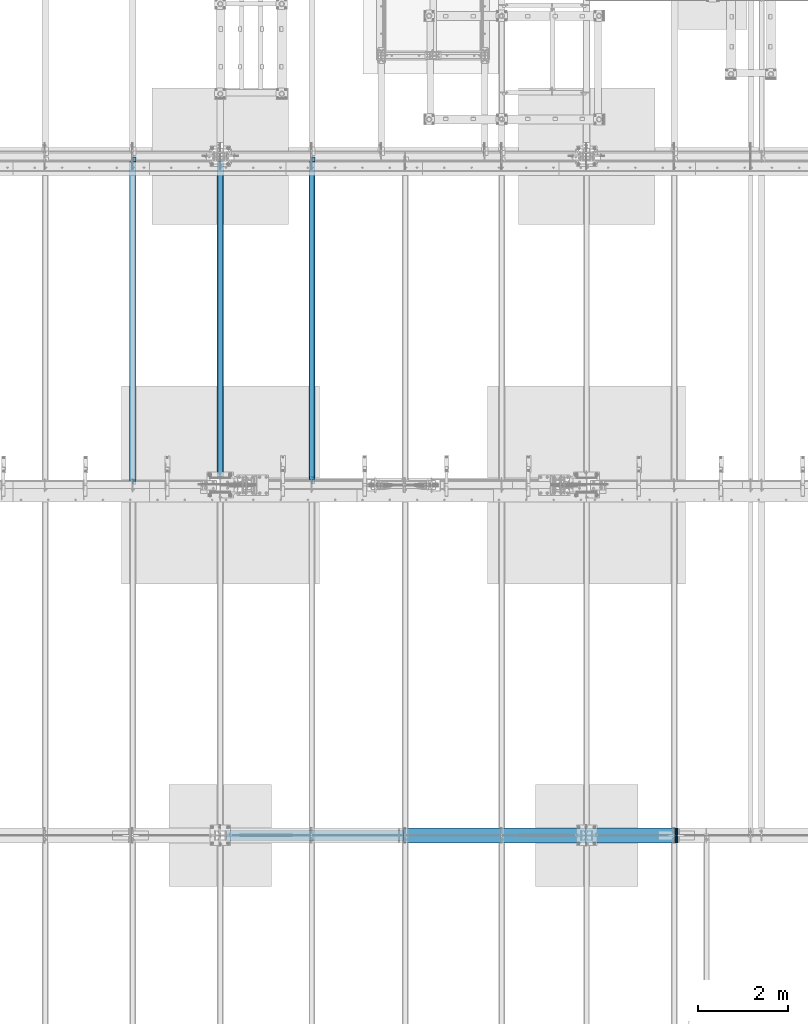
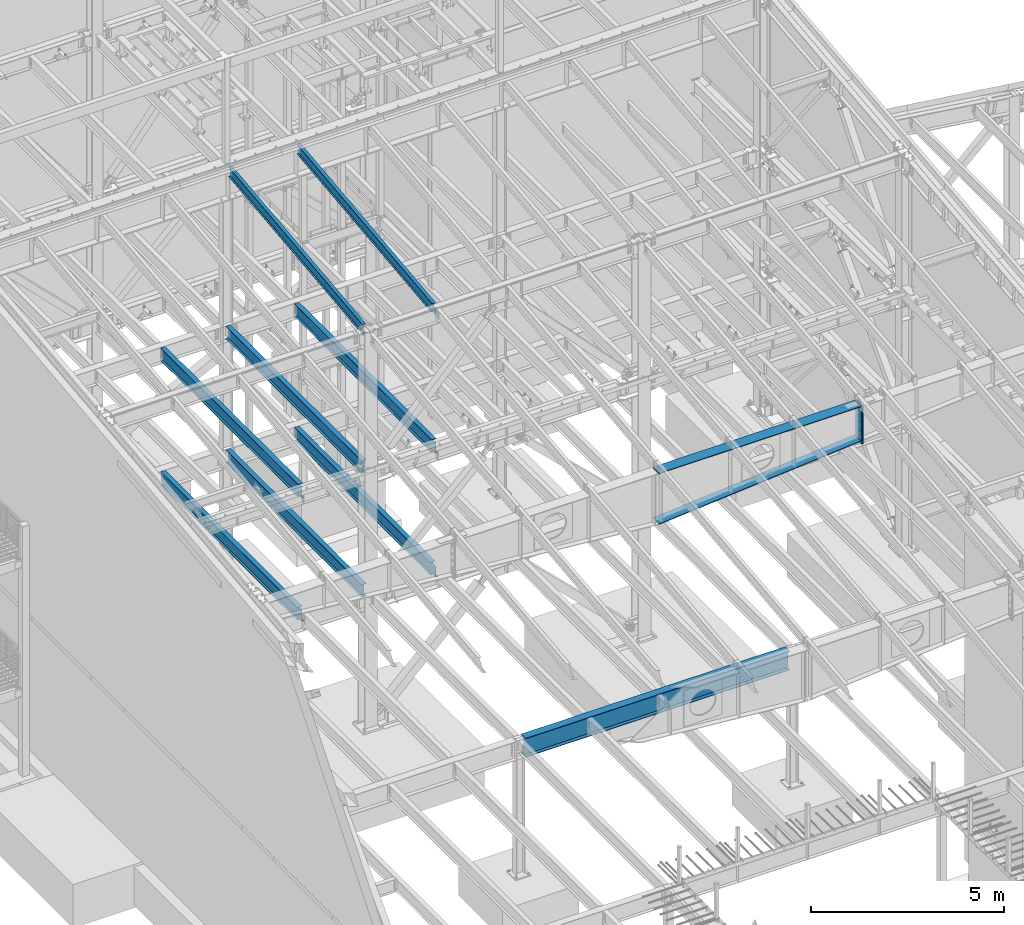
# One storey, part 733 of 1179: 13 beams, 11 elements without a shape of their own.
"""IFC2X3 building model written with IfcOpenShell, lengths in millimetres."""

import ifcopenshell
import ifcopenshell.guid

model = None  # the IFC model being written
_history = None  # IfcOwnerHistory: only IFC2X3 demands one
_inside = {}  # id of a spatial element -> (the spatial element, [elements in it])
_under = {}  # id of a project, library or spatial element -> (it, [spatial elements below it])
_declared = {}  # id of a project -> (the project, [libraries it declares])
_typed = {}  # id of a type object -> (the type object, [elements of that type])
_made_of = {}  # id of a material, layer set ... -> (it, [elements and type objects made of it])


def new_model(schema):
    """Start an empty IFC model of exactly this schema.

    Asked for "IFC4X3", IfcOpenShell would pick the latest addendum, in which some entities
    have other attributes; the version numbers below select the first issue.
    IFC2X3 requires an IfcOwnerHistory on every rooted entity: one is made here for all.
    """
    global model, _history
    if schema == "IFC4X3":
        model = ifcopenshell.file(schema_version=(4, 3, 0, 0))
    else:
        model = ifcopenshell.file(schema=schema)
    _inside.clear()
    _under.clear()
    _declared.clear()
    _typed.clear()
    _made_of.clear()
    _history = None
    if model.schema == "IFC2X3":
        org = make("IfcOrganization", Name="unknown")
        user = make(
            "IfcPersonAndOrganization",
            ThePerson=make("IfcPerson", FamilyName="unknown"),
            TheOrganization=org,
        )
        app = make(
            "IfcApplication",
            ApplicationDeveloper=org,
            Version="unknown",
            ApplicationFullName="unknown",
            ApplicationIdentifier="unknown",
        )
        _history = make(
            "IfcOwnerHistory",
            OwningUser=user,
            OwningApplication=app,
            ChangeAction="ADDED",
            CreationDate=0,
        )
    return model


def make(cls, **values):
    """One entity of the class cls with the attributes given. An attribute that is None is left unset."""
    return model.create_entity(
        cls, **{name: value for name, value in values.items() if value is not None}
    )


def rooted(cls, **values):
    """An entity with a GlobalId (a new one), such as an element, a storey or a relation."""
    return make(cls, GlobalId=ifcopenshell.guid.new(), OwnerHistory=_history, **values)


def si_unit(unit_type, name, prefix=None):
    """IfcSIUnit, for example si_unit("LENGTHUNIT", "METRE", prefix="MILLI")."""
    return make("IfcSIUnit", UnitType=unit_type, Prefix=prefix, Name=name)


def assignment(units):
    """IfcUnitAssignment: the units of a project."""
    return None if units is None else make("IfcUnitAssignment", Units=units)


def point(xyz):
    """IfcCartesianPoint."""
    return None if xyz is None else make("IfcCartesianPoint", Coordinates=xyz)


def direction(xyz):
    """IfcDirection."""
    return None if xyz is None else make("IfcDirection", DirectionRatios=xyz)


def frame(location, z_axis=None, x_axis=None):
    """IfcAxis2Placement3D, a coordinate frame: its origin and axes. An axis left out is left unset."""
    return make(
        "IfcAxis2Placement3D",
        Location=point(location),
        Axis=direction(z_axis),
        RefDirection=direction(x_axis),
    )


def origin_with_axes():
    """The frame at (0, 0, 0) with the z axis (0, 0, 1) and the x axis (1, 0, 0) written out."""
    return frame((0.0, 0.0, 0.0), z_axis=(0.0, 0.0, 1.0), x_axis=(1.0, 0.0, 0.0))


def place(relative_to, where):
    """IfcLocalPlacement: puts the frame where relative to a parent placement (None: the world)."""
    return make(
        "IfcLocalPlacement", PlacementRelTo=relative_to, RelativePlacement=where
    )


def context(
    kind, dimensions, precision=None, world=None, true_north=None, identifier=None
):
    """IfcGeometricRepresentationContext, for example the 3D "Model" context."""
    return make(
        "IfcGeometricRepresentationContext",
        ContextIdentifier=identifier,
        ContextType=kind,
        CoordinateSpaceDimension=dimensions,
        Precision=precision,
        WorldCoordinateSystem=world,
        TrueNorth=true_north,
    )


def subcontext(parent, identifier, kind, view, scale=None):
    """IfcGeometricRepresentationSubContext, for example "Body" below "Model"."""
    return make(
        "IfcGeometricRepresentationSubContext",
        ContextIdentifier=identifier,
        ContextType=kind,
        ParentContext=parent,
        TargetScale=scale,
        TargetView=view,
    )


def project(units=None, contexts=None):
    """IfcProject with its units and contexts."""
    return rooted(
        "IfcProject",
        Name="project",
        RepresentationContexts=contexts,
        UnitsInContext=assignment(units),
    )


def spatial(cls, under=None, at=None, **own):
    """A site, building, storey or space (cls), placed at a placement, below another one or the project."""
    s = rooted(cls, ObjectPlacement=at, **own)
    if under is not None:
        _under.setdefault(under.id(), (under, []))[1].append(s)
    return s


def faces_of(points, faces, orient=None, outer=None):
    """IfcFace entities. A face is a list of loops; a loop is a list of indices into points, from 0.

    orient and outer hold one flag for each loop. By default every Orientation is true, the
    first loop of a face is its IfcFaceOuterBound and the others are IfcFaceBound.
    """
    made = []
    for i, loops in enumerate(faces):
        bounds = []
        for j, loop in enumerate(loops):
            is_outer = j == 0 if outer is None else outer[i][j]
            bounds.append(
                make(
                    "IfcFaceOuterBound" if is_outer else "IfcFaceBound",
                    Bound=make("IfcPolyLoop", Polygon=[points[k] for k in loop]),
                    Orientation=True if orient is None else orient[i][j],
                )
            )
        made.append(make("IfcFace", Bounds=bounds))
    return made


def faceted_brep(points, faces, orient=None, outer=None, voids=None):
    """IfcFacetedBrep: a solid bounded by flat faces; with voids (closed shells), ...WithVoids."""
    shared = [point(p) for p in points]
    hull = make("IfcClosedShell", CfsFaces=faces_of(shared, faces, orient, outer))
    if voids is None:
        return make("IfcFacetedBrep", Outer=hull)
    return make(
        "IfcFacetedBrepWithVoids",
        Outer=hull,
        Voids=[
            make(cls, CfsFaces=faces_of(shared, fs, o, b)) for cls, fs, o, b in voids
        ],
    )


def shape(context_of_items, identifier, shape_type, items):
    """IfcShapeRepresentation: the items that make up one representation, for example the "Body"."""
    return make(
        "IfcShapeRepresentation",
        ContextOfItems=context_of_items,
        RepresentationIdentifier=identifier,
        RepresentationType=shape_type,
        Items=items,
    )


def material(Name=None, Category=None):
    """IfcMaterial."""
    return make("IfcMaterial", Name=Name, Category=Category)


def made_of(thing, what):
    """Note that an element or type object is made of a material, layer set ...; save() writes the relation."""
    if what is not None:
        _made_of.setdefault(what.id(), (what, []))[1].append(thing)
    return thing


def type_object(cls, material=None, **own):
    """A type object (cls), such as IfcWallType, which elements share."""
    return made_of(rooted(cls, **own), material)


def element(
    cls,
    number,
    at=None,
    inside=None,
    cuts=None,
    type_object=None,
    material=None,
    context=None,
    identifier="Body",
    shape_type=None,
    held_by="IfcProductDefinitionShape",
    body=None,
    shapes=None,
    **own,
):
    """One element of the class cls, such as IfcWall. Its Tag is "e" and its number.

    at: its placement. inside: the storey or other place that contains it. cuts: it is an
    opening in that element (IfcRelVoidsElement). A single representation is given by context,
    identifier, shape_type and body (its items); several are given by shapes. held_by: the class
    of the entity that holds the representations. save() writes the other relations.
    """
    e = rooted(cls, Tag="e%d" % number, ObjectPlacement=at, **own)
    if body is not None:
        shapes = [shape(context, identifier, shape_type, body)]
    if shapes is not None:
        e.Representation = make(held_by, Representations=shapes)
    if inside is not None:
        _inside.setdefault(inside.id(), (inside, []))[1].append(e)
    if cuts is not None:
        rooted(
            "IfcRelVoidsElement", RelatingBuildingElement=cuts, RelatedOpeningElement=e
        )
    if type_object is not None:
        _typed.setdefault(type_object.id(), (type_object, []))[1].append(e)
    return made_of(e, material)


def aggregate(whole, parts):
    """IfcRelAggregates: a whole, such as a stair, and the parts it consists of."""
    return rooted("IfcRelAggregates", RelatingObject=whole, RelatedObjects=parts)


def save(model, path):
    """Write the relations noted so far, then the file.

    IfcRelAggregates (storeys below a building ...), IfcRelContainedInSpatialStructure (elements
    in a storey), IfcRelDefinesByType, IfcRelAssociatesMaterial and IfcRelDeclares: one each for
    every whole, place, type object, material and project.
    """
    for whole, parts in _under.values():
        aggregate(whole, parts)
    for where, things in _inside.values():
        rooted(
            "IfcRelContainedInSpatialStructure",
            RelatedElements=things,
            RelatingStructure=where,
        )
    for kind, things in _typed.values():
        rooted("IfcRelDefinesByType", RelatedObjects=things, RelatingType=kind)
    for what, things in _made_of.values():
        rooted("IfcRelAssociatesMaterial", RelatedObjects=things, RelatingMaterial=what)
    for by, libraries in _declared.values():
        rooted("IfcRelDeclares", RelatingContext=by, RelatedDefinitions=libraries)
    model.write(path)


model = new_model("IFC2X3")

# Units and contexts
model_context = context("Model", 3, precision=1e-05, world=origin_with_axes())
body_context = subcontext(model_context, "Body", "Model", "MODEL_VIEW")
ifc_project = project(units=[si_unit("LENGTHUNIT", "METRE", prefix="MILLI"), si_unit("AREAUNIT", "SQUARE_METRE"), si_unit("VOLUMEUNIT", "CUBIC_METRE"), si_unit("MASSUNIT", "GRAM", prefix="KILO"), si_unit("TIMEUNIT", "SECOND"), si_unit("PLANEANGLEUNIT", "RADIAN"), si_unit("SOLIDANGLEUNIT", "STERADIAN"), si_unit("THERMODYNAMICTEMPERATUREUNIT", "DEGREE_CELSIUS"), si_unit("LUMINOUSINTENSITYUNIT", "LUMEN")], contexts=[model_context])

# Site, building, storey
site_placement = place(None, origin_with_axes())
site = spatial("IfcSite", under=ifc_project, at=site_placement, CompositionType="ELEMENT")
building_placement = place(site_placement, origin_with_axes())
building = spatial("IfcBuilding", under=site, at=building_placement, Name="Undefined", CompositionType="ELEMENT")
storey_placement = place(building_placement, origin_with_axes())
storey = spatial("IfcBuildingStorey", under=building, at=storey_placement, Name="Undefined", CompositionType="ELEMENT", Elevation=0.0)

# Assembly, beam
assembly_1_placement = place(storey_placement, origin_with_axes())
assembly_1 = element("IfcElementAssembly", 1, at=assembly_1_placement, inside=storey, Name="BEAM", AssemblyPlace="NOTDEFINED", PredefinedType="RIGID_FRAME")
ifc_material_1 = material(Name="STEEL/A992")
beam_type_1 = type_object("IfcBeamType", Name="W16X31", PredefinedType="NOTDEFINED")
beam_1_placement = place(assembly_1_placement, frame((10325.1, 27051.0, 7812.0875), z_axis=(0.0, 0.0, 1.0), x_axis=(0.0, 1.0, 0.0)))
beam_1 = element("IfcBeam", 2, at=beam_1_placement, type_object=beam_type_1, material=ifc_material_1, Name="BEAM", ObjectType="W16X31", context=body_context, shape_type="Brep", body=[
    faceted_brep([(105.568750190734, -3.17499999999927, 157.1625), (105.568750190734, 3.17498369619716, 157.1625), (19.84375, 3.17499999999927, 157.1625), (19.84375, -3.17499999999927, 157.1625), (110.428829708781, -3.17499999999927, 158.129229922588), (110.428829708781, 3.17498323778818, 158.129229922588), (114.549006176934, -3.17499999999927, 160.882243823066), (114.549006176934, 3.17498193235224, 160.882243823066), (117.302020077412, -3.17499999999927, 165.00242029122), (117.302020077412, 3.17497997862665, 165.00242029122), (118.268749999999, -3.17499999999927, 169.862499809266), (118.268749999999, 3.17497767405257, 169.862499809266), (118.268749999999, -69.8500000000004, 201.6125), (118.268749999999, 69.8500000000004, 201.6125), (118.268749999999, 69.8500000000004, 190.5), (118.268749999999, 3.17499999999927, 190.5), (118.268749999999, -3.17499999999927, 190.5), (118.268749999999, -69.8500000000004, 190.5), (7196.1375, 3.17499999999927, -190.5), (7196.1375, 69.8500000000004, -190.5), (146.84375, 69.8500000000004, -190.5), (146.843749999996, 3.17549991607484, -190.5), (19.84375, -3.17499999999927, -190.5), (19.84375, -69.8500000000004, -190.5), (7323.1375, -69.8500000000004, -190.5), (7323.1375, -3.17499999999927, -190.5), (19.84375, -69.8500000000004, -201.6125), (7323.1375, -69.8500000000004, -201.6125), (7196.1375, 69.8500000000004, -201.6125), (7196.1375, 3.17549991607484, -201.6125), (7323.1375, 3.17549991607484, -201.6125), (19.84375, 3.17549991607484, -201.6125), (146.843749999996, 3.17549991607484, -201.6125), (146.84375, 69.8500000000004, -201.6125), (19.84375, 3.17499999999927, -190.5), (7323.1375, 3.17499999999927, -190.5), (7323.1375, 3.17499999999927, 166.6875), (7323.1375, -3.17499999999927, 166.6875), (7235.82499980928, 3.17499999999927, 166.6875), (7235.82499980928, -3.17499999999927, 166.6875), (7230.96492029123, 3.17499999999927, 167.654229922588), (7230.96492029123, -3.17499999999927, 167.654229922588), (7226.84474382308, 3.17499999999927, 170.407243823066), (7226.84474382308, -3.17499999999927, 170.407243823066), (7224.0917299226, 3.17499999999927, 174.52742029122), (7224.0917299226, -3.17499999999927, 174.52742029122), (7223.12500000001, 3.17499999999927, 179.387499809265), (7223.12500000001, -3.17499999999927, 179.387499809265), (7223.12500000001, -69.8500000000004, 201.6125), (7223.12500000001, -69.8500000000004, 190.5), (7223.12500000001, -3.17499999999927, 190.5), (7223.12500000001, 3.17499999999927, 190.5), (7223.12500000001, 69.8500000000004, 190.5), (7223.12500000001, 69.8500000000004, 201.6125)], [[[0, 1, 2, 3]], [[4, 5, 1, 0]], [[6, 7, 5, 4]], [[8, 9, 7, 6]], [[10, 11, 9, 8]], [[12, 13, 14, 15, 11, 10, 16, 17]], [[18, 19, 20, 21]], [[22, 23, 24, 25]], [[23, 26, 27, 24]], [[28, 29, 30, 27, 26, 31, 32, 33]], [[21, 32, 31, 34]], [[20, 33, 32, 21]], [[19, 28, 33, 20]], [[18, 29, 28, 19]], [[35, 30, 29, 18]], [[25, 24, 27, 30, 35, 36, 37]], [[37, 36, 38, 39]], [[39, 38, 40, 41]], [[41, 40, 42, 43]], [[43, 42, 44, 45]], [[45, 44, 46, 47]], [[48, 49, 50, 47, 46, 51, 52, 53]], [[49, 48, 12, 17]], [[50, 49, 17, 16]], [[8, 6, 4, 0, 3, 22, 25, 37, 39, 41, 43, 45, 47, 50, 16, 10]], [[34, 31, 26, 23, 22, 3, 2]], [[51, 46, 44, 42, 40, 38, 36, 35, 18, 21, 34, 2, 1, 5, 7, 9, 11, 15]], [[52, 51, 15, 14]], [[53, 52, 14, 13]], [[48, 53, 13, 12]]]),
])
aggregate(assembly_1, [beam_1])

assembly_2_placement = place(storey_placement, origin_with_axes())
assembly_2 = element("IfcElementAssembly", 3, at=assembly_2_placement, inside=storey, Name="BEAM", AssemblyPlace="NOTDEFINED", PredefinedType="RIGID_FRAME")
beam_2_placement = place(assembly_2_placement, frame((8280.4, 27051.0, 7812.0875), z_axis=(0.0, 0.0, 1.0), x_axis=(0.0, 1.0, 0.0)))
beam_2 = element("IfcBeam", 4, at=beam_2_placement, type_object=beam_type_1, material=ifc_material_1, Name="BEAM", ObjectType="W16X31", context=body_context, shape_type="Brep", body=[
    faceted_brep([(195.262500000001, -69.8499999999985, -201.6125), (195.262500000001, 69.8499999999985, -201.6125), (7224.7125, 69.8499999999985, -201.6125), (7224.7125, -69.8499999999985, -201.6125), (195.262500000001, -69.8499999999985, -190.5), (195.262500000001, -3.17499999999927, -190.5), (195.262500000001, -3.17499999999927, 190.5), (195.262500000001, -69.8499999999985, 190.5), (195.262500000001, -69.8499999999985, 201.6125), (195.262500000001, 69.8499999999985, 201.6125), (195.262500000001, 69.8499999999985, 190.5), (195.262500000001, 3.17499999999927, 190.5), (195.262500000001, 3.17499999999927, -190.5), (195.262500000001, 69.8499999999985, -190.5), (7224.7125, -69.8499999999985, -190.5), (7224.7125, -3.17499999999927, -190.5), (7224.7125, -3.17499999999927, 190.5), (7224.7125, -69.8499999999985, 190.5), (7224.7125, -69.8499999999985, 201.6125), (7224.7125, 69.8499999999985, 201.6125), (7224.7125, 69.8499999999985, 190.5), (7224.7125, 3.17499999999927, 190.5), (7224.7125, 3.17499999999927, 164.252489941818), (7224.7125, 3.17499999999927, -142.027503290603), (7224.7125, 3.17499999999927, -190.5), (7224.7125, 69.8499999999985, -190.5)], [[[0, 1, 2, 3]], [[0, 4, 5, 6, 7, 8, 9, 10, 11, 12, 13, 1]], [[5, 4, 14, 15]], [[6, 5, 15, 16]], [[7, 6, 16, 17]], [[8, 7, 17, 18]], [[9, 8, 18, 19]], [[10, 9, 19, 20]], [[11, 10, 20, 21]], [[12, 11, 21, 22, 23, 24]], [[13, 12, 24, 25]], [[1, 13, 25, 2]], [[24, 23, 22, 21, 20, 19, 18, 17, 16, 15, 14, 3, 2, 25]], [[4, 0, 3, 14]]]),
])
aggregate(assembly_2, [beam_2])

assembly_3_placement = place(storey_placement, origin_with_axes())
assembly_3 = element("IfcElementAssembly", 5, at=assembly_3_placement, inside=storey, Name="BEAM", AssemblyPlace="NOTDEFINED", PredefinedType="RIGID_FRAME")
beam_3_placement = place(assembly_3_placement, frame((6324.6, 27051.0, 7812.0875), z_axis=(0.0, 0.0, 1.0), x_axis=(0.0, 1.0, 0.0)))
beam_3 = element("IfcBeam", 6, at=beam_3_placement, type_object=beam_type_1, material=ifc_material_1, Name="BEAM", ObjectType="W16X31", context=body_context, shape_type="Brep", body=[
    faceted_brep([(82.5499999999993, -3.17500000000291, 166.6875), (82.5499999999993, 3.17500000000291, 166.6875), (17.4624999999942, 3.17499999999927, 166.6875), (17.4624999999942, -3.17499999999927, 166.6875), (87.4100797087813, -3.17499999999927, 167.654229922588), (87.4100797087813, 3.17497144083973, 167.654229922588), (91.5302561769349, -3.17499999999927, 170.407243823066), (91.5302561769349, 3.17496966460385, 170.407243823066), (94.2832700774125, -3.17499999999927, 174.52742029122), (94.2832700774125, 3.1749670062818, 174.52742029122), (95.25, -3.17499999999927, 179.387499809265), (95.25, 3.1749638705769, 179.387499809265), (95.25, -69.8499999999985, 201.6125), (95.25, 69.8499999999985, 201.6125), (95.25, 69.8499999999985, 190.5), (95.25, 3.17499999999927, 190.5), (95.25, -3.17499999999927, 190.5), (95.25, -69.8499999999985, 190.5), (7196.1375, 3.17499999999927, -190.5), (7196.1375, 69.8500000000004, -190.5), (144.462499999994, 69.8499999999985, -190.5), (144.462499999994, 3.17549991607666, -190.5), (17.4624999999942, -3.17499999999927, -190.5), (17.4624999999942, -69.8499999999985, -190.5), (7323.1375, -69.8500000000004, -190.5), (7323.1375, -3.17499999999927, -190.5), (17.4624999999942, -69.8499999999985, -201.6125), (7323.1375, -69.8500000000004, -201.6125), (7196.1375, 69.8500000000004, -201.6125), (7196.1375, 3.17549991607484, -201.6125), (7323.1375, 3.17549991607484, -201.6125), (17.4624999999942, 3.17549991607666, -201.6125), (144.462499999994, 3.17549991607666, -201.6125), (144.462499999994, 69.8499999999985, -201.6125), (17.4624999999942, 3.17499999999927, -190.5), (7323.1375, 3.17499999999927, -190.5), (7323.1375, 3.17499999999927, 166.6875), (7323.1375, -3.17499999999927, 166.6875), (7235.82499980928, 3.17499999999927, 166.6875), (7235.82499980928, -3.17499999999927, 166.6875), (7230.96492029123, 3.17499999999927, 167.654229922588), (7230.96492029123, -3.17499999999927, 167.654229922588), (7226.84474382308, 3.17499999999927, 170.407243823066), (7226.84474382308, -3.17499999999927, 170.407243823066), (7224.0917299226, 3.17499999999927, 174.52742029122), (7224.0917299226, -3.17499999999927, 174.52742029122), (7223.12500000001, 3.17499999999927, 179.387499809265), (7223.12500000001, -3.17499999999927, 179.387499809265), (7223.12500000001, -69.8500000000004, 201.6125), (7223.12500000001, -69.8500000000004, 190.5), (7223.12500000001, -3.17499999999927, 190.5), (7223.12500000001, 3.17499999999927, 190.5), (7223.12500000001, 69.8500000000004, 190.5), (7223.12500000001, 69.8500000000004, 201.6125)], [[[0, 1, 2, 3]], [[4, 5, 1, 0]], [[6, 7, 5, 4]], [[8, 9, 7, 6]], [[10, 11, 9, 8]], [[12, 13, 14, 15, 11, 10, 16, 17]], [[18, 19, 20, 21]], [[22, 23, 24, 25]], [[23, 26, 27, 24]], [[28, 29, 30, 27, 26, 31, 32, 33]], [[21, 32, 31, 34]], [[20, 33, 32, 21]], [[19, 28, 33, 20]], [[18, 29, 28, 19]], [[35, 30, 29, 18]], [[25, 24, 27, 30, 35, 36, 37]], [[37, 36, 38, 39]], [[39, 38, 40, 41]], [[41, 40, 42, 43]], [[43, 42, 44, 45]], [[45, 44, 46, 47]], [[48, 49, 50, 47, 46, 51, 52, 53]], [[49, 48, 12, 17]], [[50, 49, 17, 16]], [[8, 6, 4, 0, 3, 22, 25, 37, 39, 41, 43, 45, 47, 50, 16, 10]], [[34, 31, 26, 23, 22, 3, 2]], [[51, 46, 44, 42, 40, 38, 36, 35, 18, 21, 34, 2, 1, 5, 7, 9, 11, 15]], [[52, 51, 15, 14]], [[53, 52, 14, 13]], [[48, 53, 13, 12]]]),
])
aggregate(assembly_3, [beam_3])

assembly_4_placement = place(storey_placement, origin_with_axes())
assembly_4 = element("IfcElementAssembly", 7, at=assembly_4_placement, inside=storey, Name="BEAM", AssemblyPlace="NOTDEFINED", PredefinedType="RIGID_FRAME")
beam_4_placement = place(assembly_4_placement, frame((10325.1001686096, 27046.2375, 3900.4875), z_axis=(0.0, 0.0, 1.0), x_axis=(0.0, 1.0, 0.0)))
beam_4 = element("IfcBeam", 8, at=beam_4_placement, type_object=beam_type_1, material=ifc_material_1, Name="BEAM", ObjectType="W16X31", context=body_context, shape_type="Brep", body=[
    faceted_brep([(168.275000190741, -3.17499999999927, 163.512499999999), (168.275000190741, 3.17497466870009, 163.512499999999), (25.4000000000015, 3.17499999999927, 163.512499999999), (25.4000000000015, -3.17499999999927, 163.512499999999), (173.135079708787, -3.17499999999927, 164.479229922587), (173.135079708787, 3.17497404500864, 164.479229922587), (177.255256176941, -3.17499999999927, 167.232243823065), (177.255256176941, 3.17497226888918, 167.232243823065), (180.008270077418, -3.17499999999927, 171.352420291219), (180.008270077418, 3.17496961073812, 171.352420291219), (180.975000000006, -3.17499999999927, 176.212499809265), (180.975000000006, 3.1749664752333, 176.212499809265), (180.975000000006, -69.8500000000004, 201.6125), (180.975000000006, 69.8500000000004, 201.6125), (180.975000000006, 69.8500000000004, 190.5), (180.975000000006, 3.17499999999927, 190.5), (180.975000000006, -3.17499999999927, 190.5), (180.975000000006, -69.8500000000004, 190.5), (7200.10625, 3.17499999999927, -190.5), (7200.10625, 69.8500000000004, -190.5), (180.975000000002, 69.8500000000004, -190.5), (180.975000000002, 3.17549991607484, -190.5), (25.4000000000015, -3.17499999999927, -190.5), (25.4000000000015, -69.8500000000004, -190.5), (7327.10625, -69.8500000000004, -190.5), (7327.10625, -3.17499999999927, -190.5), (25.4000000000015, -69.8500000000004, -201.6125), (7327.10625, -69.8500000000004, -201.6125), (7200.10625, 69.8500000000004, -201.6125), (7200.10625, 3.17549991607666, -201.6125), (7327.10625, 3.17549991607666, -201.6125), (25.4000000000015, 3.17549991607484, -201.6125), (180.975000000002, 3.17549991607484, -201.6125), (180.975000000002, 69.8500000000004, -201.6125), (25.4000000000015, 3.17499999999927, -190.5), (7327.10625, 3.17499999999927, -190.5), (7327.10625, 3.17499999999927, 169.8625), (7327.10625, -3.17499999999927, 169.8625), (7231.85624980925, 3.17499999999927, 169.8625), (7231.85624980925, -3.17499999999927, 169.8625), (7226.99617029121, 3.17499999999927, 170.829229922588), (7226.99617029121, -3.17499999999927, 170.829229922588), (7222.87599382305, 3.17499999999927, 173.582243823066), (7222.87599382305, -3.17499999999927, 173.582243823066), (7220.12297992257, 3.17499999999927, 177.70242029122), (7220.12297992257, -3.17499999999927, 177.70242029122), (7219.15624999999, 3.17499999999927, 182.562499809265), (7219.15624999999, -3.17499999999927, 182.562499809265), (7219.15624999999, -69.8500000000004, 201.6125), (7219.15624999999, -69.8500000000004, 190.5), (7219.15624999999, -3.17499999999927, 190.5), (7219.15624999999, 3.17499999999927, 190.5), (7219.15624999999, 69.8500000000004, 190.5), (7219.15624999999, 69.8500000000004, 201.6125)], [[[0, 1, 2, 3]], [[4, 5, 1, 0]], [[6, 7, 5, 4]], [[8, 9, 7, 6]], [[10, 11, 9, 8]], [[12, 13, 14, 15, 11, 10, 16, 17]], [[18, 19, 20, 21]], [[22, 23, 24, 25]], [[23, 26, 27, 24]], [[28, 29, 30, 27, 26, 31, 32, 33]], [[21, 32, 31, 34]], [[20, 33, 32, 21]], [[19, 28, 33, 20]], [[18, 29, 28, 19]], [[35, 30, 29, 18]], [[25, 24, 27, 30, 35, 36, 37]], [[37, 36, 38, 39]], [[39, 38, 40, 41]], [[41, 40, 42, 43]], [[43, 42, 44, 45]], [[45, 44, 46, 47]], [[48, 49, 50, 47, 46, 51, 52, 53]], [[49, 48, 12, 17]], [[50, 49, 17, 16]], [[8, 6, 4, 0, 3, 22, 25, 37, 39, 41, 43, 45, 47, 50, 16, 10]], [[34, 31, 26, 23, 22, 3, 2]], [[51, 46, 44, 42, 40, 38, 36, 35, 18, 21, 34, 2, 1, 5, 7, 9, 11, 15]], [[52, 51, 15, 14]], [[53, 52, 14, 13]], [[48, 53, 13, 12]]]),
])
aggregate(assembly_4, [beam_4])

assembly_5_placement = place(storey_placement, origin_with_axes())
assembly_5 = element("IfcElementAssembly", 9, at=assembly_5_placement, inside=storey, Name="BEAM", AssemblyPlace="NOTDEFINED", PredefinedType="RIGID_FRAME")
beam_5_placement = place(assembly_5_placement, frame((8280.4, 27051.0, 3900.4875), z_axis=(0.0, 0.0, 1.0), x_axis=(0.0, 1.0, 0.0)))
beam_5 = element("IfcBeam", 10, at=beam_5_placement, type_object=beam_type_1, material=ifc_material_1, Name="BEAM", ObjectType="W16X31", context=body_context, shape_type="Brep", body=[
    faceted_brep([(195.371510976522, -69.8500000000004, -201.6125), (195.371510976522, 69.8500000000004, -201.6125), (7224.7125, 69.8499999999985, -201.6125), (7224.7125, -69.8499999999985, -201.6125), (195.371510976522, -69.8500000000004, -190.5), (195.371510976522, -3.17499999999927, -190.5), (195.371510976522, -3.17499999999927, 190.5), (195.371510976522, -69.8500000000004, 190.5), (195.371510976522, -69.8500000000004, 201.6125), (195.371510976522, 69.8500000000004, 201.6125), (195.371510976522, 69.8500000000004, 190.5), (195.371510976522, 3.17499999999927, 190.5), (195.371510976522, 3.17499999999927, -190.5), (195.371510976522, 69.8500000000004, -190.5), (7224.7125, -69.8499999999985, -190.5), (7224.7125, -3.17499999999927, -190.5), (7224.7125, -3.17499999999927, 190.5), (7224.7125, -69.8499999999985, 190.5), (7224.7125, -69.8499999999985, 201.6125), (7224.7125, 69.8499999999985, 201.6125), (7224.7125, 69.8499999999985, 190.5), (7224.7125, 3.17499999999927, 190.5), (7224.7125, 3.17499999999927, 164.252489941818), (7224.7125, 3.17499999999927, -142.027503290603), (7224.7125, 3.17499999999927, -190.5), (7224.7125, 69.8499999999985, -190.5)], [[[0, 1, 2, 3]], [[0, 4, 5, 6, 7, 8, 9, 10, 11, 12, 13, 1]], [[5, 4, 14, 15]], [[6, 5, 15, 16]], [[7, 6, 16, 17]], [[8, 7, 17, 18]], [[9, 8, 18, 19]], [[10, 9, 19, 20]], [[11, 10, 20, 21]], [[12, 11, 21, 22, 23, 24]], [[13, 12, 24, 25]], [[1, 13, 25, 2]], [[24, 23, 22, 21, 20, 19, 18, 17, 16, 15, 14, 3, 2, 25]], [[4, 0, 3, 14]]]),
])
aggregate(assembly_5, [beam_5])

assembly_6_placement = place(storey_placement, origin_with_axes())
assembly_6 = element("IfcElementAssembly", 11, at=assembly_6_placement, inside=storey, Name="BEAM", AssemblyPlace="NOTDEFINED", PredefinedType="RIGID_FRAME")
beam_6_placement = place(assembly_6_placement, frame((6324.59996643066, 27046.2375, 3900.4875), z_axis=(0.0, 0.0, 1.0), x_axis=(0.0, 1.0, 0.0)))
beam_6 = element("IfcBeam", 12, at=beam_6_placement, type_object=beam_type_1, material=ifc_material_1, Name="BEAM", ObjectType="W16X31", context=body_context, shape_type="Brep", body=[
    faceted_brep([(119.062500190743, -3.17500000000018, 169.8625), (119.062500190743, 3.17497080806788, 169.8625), (23.8125, 3.17500000000018, 169.8625), (23.8125, -3.17500000000018, 169.8625), (123.922579708789, -3.17500000000018, 170.829229922588), (123.922579708789, 3.17497018437552, 170.829229922588), (128.042756176943, -3.17500000000018, 173.582243823066), (128.042756176943, 3.17496840824879, 173.582243823066), (130.79577007742, -3.17500000000018, 177.70242029122), (130.79577007742, 3.17496575008772, 177.70242029122), (131.762500000008, -3.17500000000018, 182.562499809265), (131.762500000008, 3.17496261457291, 182.562499809265), (131.762500000008, -69.8500000000004, 201.6125), (131.762500000008, 69.8500000000004, 201.6125), (131.762500000008, 69.8500000000004, 190.5), (131.762500000008, 3.17500000000018, 190.5), (131.762500000008, -3.17500000000018, 190.5), (131.762500000008, -69.8500000000004, 190.5), (7200.10625, 3.17499999999927, -190.5), (7200.10625, 69.8500000000004, -190.5), (150.812499999996, 69.8500000000004, -190.5), (150.812499999996, 3.17549991607575, -190.5), (23.8125, -3.17500000000018, -190.5), (23.8125, -69.8500000000004, -190.5), (7327.10625, -69.8500000000004, -190.5), (7327.10625, -3.17499999999927, -190.5), (23.8125, -69.8500000000004, -201.6125), (7327.10625, -69.8500000000004, -201.6125), (7200.10625, 69.8500000000004, -201.6125), (7200.10625, 3.17549991607666, -201.6125), (7327.10625, 3.17549991607666, -201.6125), (23.8125, 3.17549991607575, -201.6125), (150.812499999996, 3.17549991607575, -201.6125), (150.812499999996, 69.8500000000004, -201.6125), (23.8125, 3.17500000000018, -190.5), (7327.10625, 3.17499999999927, -190.5), (7327.10625, 3.17499999999927, 169.8625), (7327.10625, -3.17499999999927, 169.8625), (7231.85624980925, 3.17499999999927, 169.8625), (7231.85624980925, -3.17499999999927, 169.8625), (7226.99617029121, 3.17499999999927, 170.829229922588), (7226.99617029121, -3.17499999999927, 170.829229922588), (7222.87599382305, 3.17499999999927, 173.582243823066), (7222.87599382305, -3.17499999999927, 173.582243823066), (7220.12297992257, 3.17499999999927, 177.70242029122), (7220.12297992257, -3.17499999999927, 177.70242029122), (7219.15624999999, 3.17499999999927, 182.562499809265), (7219.15624999999, -3.17499999999927, 182.562499809265), (7219.15624999999, -69.8500000000004, 201.6125), (7219.15624999999, -69.8500000000004, 190.5), (7219.15624999999, -3.17499999999927, 190.5), (7219.15624999999, 3.17499999999927, 190.5), (7219.15624999999, 69.8500000000004, 190.5), (7219.15624999999, 69.8500000000004, 201.6125)], [[[0, 1, 2, 3]], [[4, 5, 1, 0]], [[6, 7, 5, 4]], [[8, 9, 7, 6]], [[10, 11, 9, 8]], [[12, 13, 14, 15, 11, 10, 16, 17]], [[18, 19, 20, 21]], [[22, 23, 24, 25]], [[23, 26, 27, 24]], [[28, 29, 30, 27, 26, 31, 32, 33]], [[21, 32, 31, 34]], [[20, 33, 32, 21]], [[19, 28, 33, 20]], [[18, 29, 28, 19]], [[35, 30, 29, 18]], [[25, 24, 27, 30, 35, 36, 37]], [[37, 36, 38, 39]], [[39, 38, 40, 41]], [[41, 40, 42, 43]], [[43, 42, 44, 45]], [[45, 44, 46, 47]], [[48, 49, 50, 47, 46, 51, 52, 53]], [[49, 48, 12, 17]], [[50, 49, 17, 16]], [[8, 6, 4, 0, 3, 22, 25, 37, 39, 41, 43, 45, 47, 50, 16, 10]], [[34, 31, 26, 23, 22, 3, 2]], [[51, 46, 44, 42, 40, 38, 36, 35, 18, 21, 34, 2, 1, 5, 7, 9, 11, 15]], [[52, 51, 15, 14]], [[53, 52, 14, 13]], [[48, 53, 13, 12]]]),
])
aggregate(assembly_6, [beam_6])

assembly_7_placement = place(storey_placement, origin_with_axes())
assembly_7 = element("IfcElementAssembly", 13, at=assembly_7_placement, inside=storey, Name="RAFTER BEAM", AssemblyPlace="NOTDEFINED", PredefinedType="RIGID_FRAME")
ifc_material_2 = material(Name="STEEL/A36")
beam_type_2 = type_object("IfcBeamType", PredefinedType="NOTDEFINED")
beam_7_placement = place(assembly_7_placement, frame((18453.1, 19392.8999999987, 10522.74375), z_axis=(0.0, 0.0, 1.0), x_axis=(0.0, -1.0, 0.0)))
beam_7 = element("IfcBeam", 14, at=beam_7_placement, type_object=beam_type_2, material=ifc_material_2, Name="PLATE", context=body_context, shape_type="Brep", body=[
    faceted_brep([(0.0, 12.7000000000007, -604.8375), (0.0, 12.7000000000007, 604.8375), (330.199999998662, 12.7000000000007, 604.8375), (330.199999998662, 12.7000000000007, -604.8375), (0.0, -12.7000000000007, 604.8375), (330.199999998662, -12.7000000000007, 604.8375), (0.0, -12.7000000000007, -604.8375), (330.199999998662, -12.7000000000007, -604.8375)], [[[0, 1, 2, 3]], [[1, 4, 5, 2]], [[4, 6, 7, 5]], [[6, 0, 3, 7]], [[5, 7, 3, 2]], [[6, 4, 1, 0]]]),
])

assembly_8_placement = place(storey_placement, origin_with_axes())
assembly_8 = element("IfcElementAssembly", 15, at=assembly_8_placement, inside=storey, Name="RAFTER BEAM", AssemblyPlace="NOTDEFINED", PredefinedType="RIGID_FRAME")
beam_8_placement = place(assembly_8_placement, frame((18478.5, 19392.8999999987, 10522.74375), z_axis=(0.0, 0.0, 1.0), x_axis=(0.0, -1.0, 0.0)))
beam_8 = element("IfcBeam", 16, at=beam_8_placement, type_object=beam_type_2, material=ifc_material_2, Name="PLATE", context=body_context, shape_type="Brep", body=[
    faceted_brep([(0.0, 12.7000000000007, -604.8375), (0.0, 12.7000000000007, 604.8375), (330.199999998662, 12.7000000000007, 604.8375), (330.199999998662, 12.7000000000007, -604.8375), (0.0, -12.7000000000007, 604.8375), (330.199999998662, -12.7000000000007, 604.8375), (0.0, -12.7000000000007, -604.8375), (330.199999998662, -12.7000000000007, -604.8375)], [[[0, 1, 2, 3]], [[1, 4, 5, 2]], [[4, 6, 7, 5]], [[6, 0, 3, 7]], [[5, 7, 3, 2]], [[6, 4, 1, 0]]]),
])
aggregate(assembly_8, [beam_8])

# Beam
beam_type_3 = type_object("IfcBeamType", PredefinedType="NOTDEFINED")
beam_9_placement = place(assembly_7_placement, frame((12370.7428862919, 19227.7999999958, 9513.13382343051), z_axis=(0.0, 1.0, 0.0), x_axis=(0.996393807714311, 0.0, 0.0848491599756719)))
beam_9 = element("IfcBeam", 17, at=beam_9_placement, type_object=beam_type_3, material=ifc_material_2, Name="PLATE", context=body_context, shape_type="Brep", body=[
    faceted_brep([(6090.71942911093, 11.0885263453838, 165.1), (6072.00277546247, -11.112499998424, 165.1), (6072.00277546247, -11.112499998424, -165.1), (6090.6783848247, 11.1125000015836, -165.1), (18.7420566108085, 11.1124996782601, 165.1), (18.7420566108103, 11.1125000000056, -165.1), (1.66062363859965e-09, -11.1125000000084, -165.1), (1.66062363859965e-09, -11.1125000000084, 165.1)], [[[0, 1, 2, 3]], [[4, 5, 6, 7]], [[5, 4, 0, 3]], [[6, 5, 3, 2]], [[7, 6, 2, 1]], [[4, 7, 1, 0]]]),
])

beam_10_placement = place(assembly_7_placement, frame((12369.8, 19227.7999999987, 11116.4687496185), z_axis=(0.0, -1.0, 0.0), x_axis=(1.0, 0.0, 0.0)))
beam_10 = element("IfcBeam", 18, at=beam_10_placement, type_object=beam_type_3, material=ifc_material_2, Name="PLATE", context=body_context, shape_type="Brep", body=[
    faceted_brep([(6070.6, -11.1124999999993, 165.1), (6070.6, -11.1124999999993, -165.1), (6048.37499961853, 11.1124999999993, -165.1), (6048.37499961853, 11.1125000014017, 165.1), (22.2250003814697, 11.1125003814705, 165.1), (22.2250003814697, 11.1124999999993, -165.1), (1.66062363859965e-09, -11.1125000000084, -165.1), (1.66062363859965e-09, -11.1125000000084, 165.1)], [[[0, 1, 2, 3]], [[4, 5, 6, 7]], [[4, 7, 0, 3]], [[5, 4, 3, 2]], [[6, 5, 2, 1]], [[7, 6, 1, 0]]]),
])

aggregate(assembly_7, [beam_7, beam_9, beam_10])

# Assembly, beam
assembly_9_placement = place(storey_placement, origin_with_axes())
assembly_9 = element("IfcElementAssembly", 19, at=assembly_9_placement, inside=storey, Name="BEAM", AssemblyPlace="NOTDEFINED", PredefinedType="RIGID_FRAME")
beam_type_4 = type_object("IfcBeamType", Name="W12X22", PredefinedType="NOTDEFINED")
beam_11_placement = place(assembly_9_placement, frame((10325.1, 27068.4779321143, 12149.0171463666), z_axis=(0.0, -0.112284087038017, 0.993676146336441), x_axis=(0.0, 0.993676146336441, 0.112284087038017)))
beam_11 = element("IfcBeam", 20, at=beam_11_placement, type_object=beam_type_4, material=ifc_material_1, Name="BEAM", ObjectType="W12X22", context=body_context, shape_type="Brep", body=[
    faceted_brep([(-15.5407998117698, -3.17499999999927, -144.462499999911), (-16.7964975778959, -3.17487472700668, -155.574999999904), (135.603493906594, -3.17489667232439, -155.574999999968), (135.603493906547, -3.17499999999927, -144.462499999972), (135.603487048622, -50.7999999999993, -144.462499999972), (135.603487048618, -50.7999999999993, -155.574999999964), (7139.32426989316, 3.17499999999927, -144.462500002814), (7139.32426989316, 50.7999999999993, -144.462500002814), (135.603501703274, 50.7999999999993, -144.462499999974), (135.603494845222, 3.17489668907729, -144.462500001895), (135.603494845269, 3.17510329651486, -155.574999999966), (-16.7964975778959, 3.17512524196718, -155.574999999904), (-15.5407998117698, 3.17499999999927, -144.462499999911), (135.603501703274, 50.7999999999993, -155.574999999966), (7138.06857212703, 50.7999999999993, -155.575000002807), (7142.71544233383, 3.17499999999927, -114.451772291532), (7168.54976507951, 3.17499999999927, 114.173235457372), (7171.97241181248, 3.17499999999927, 144.462499997011), (7171.97241181248, 50.7999999999993, 144.462499997011), (7173.22810957861, 50.7999999999993, 155.574999997003), (7173.22810957861, -50.7999999999993, 155.574999997003), (7171.97241181248, -50.7999999999993, 144.462499997011), (7171.97241181248, -3.17499999999927, 144.462499997011), (7139.32426989316, -3.17499999999927, -144.462500002814), (7139.32426989316, -50.7999999999993, -144.462500002814), (7138.06857212703, -50.7999999999993, -155.575000002807), (-14.7372101429282, -3.17499999999927, -137.351003558748), (10.2521606948103, -3.17499999999927, 83.7964659398294), (10.2521606948103, 3.17499999999927, 83.7964659398294), (-14.7371967980653, 3.17499999999927, -137.350885461223), (92.2801267643408, -3.17499999999927, 74.5274145334315), (92.2801267643408, 3.17499999999927, 74.5274145334315), (97.2180202374875, -3.17499999999927, 74.9423214058406), (97.2180202374875, 3.17499999999927, 74.9423214058406), (101.621260964999, -3.17499999999927, 77.215295396114), (101.621260964999, 3.17499999999927, 77.215295396114), (104.819495461597, -3.17499999999927, 81.0002968187928), (104.819495461597, 3.17499999999927, 81.0002968187928), (106.325821517235, -3.17499999999927, 85.7210935183975), (106.325821517235, 3.17499999999927, 85.7210935183975), (112.963522565431, 3.17499999999927, 144.462499999876), (112.963522565431, 50.7999999999993, 144.462499999876), (114.219220331557, 50.7999999999993, 155.57499999987), (114.219220331557, -50.7999999999993, 155.57499999987), (112.963522565431, -50.7999999999993, 144.462499999876), (112.963522565431, -3.17499999999927, 144.462499999876)], [[[0, 1, 2, 3]], [[4, 3, 2, 5]], [[6, 7, 8, 9]], [[9, 10, 11, 12]], [[8, 13, 10, 9]], [[7, 14, 13, 8]], [[6, 15, 16, 17, 18, 19, 20, 21, 22, 23, 24, 25, 14, 7]], [[25, 24, 4, 5]], [[1, 11, 10, 13, 14, 25, 5, 2]], [[26, 27, 28, 29, 12, 11, 1, 0]], [[30, 31, 28, 27]], [[32, 33, 31, 30]], [[34, 35, 33, 32]], [[36, 37, 35, 34]], [[38, 39, 37, 36]], [[17, 16, 15, 6, 9, 12, 29, 28, 31, 33, 35, 37, 39, 40]], [[18, 17, 40, 41]], [[19, 18, 41, 42]], [[20, 19, 42, 43]], [[21, 20, 43, 44]], [[22, 21, 44, 45]], [[43, 42, 41, 40, 39, 38, 45, 44]], [[36, 34, 32, 30, 27, 26, 0, 3, 23, 22, 45, 38]], [[24, 23, 3, 4]]]),
])
aggregate(assembly_9, [beam_11])

assembly_10_placement = place(storey_placement, origin_with_axes())
assembly_10 = element("IfcElementAssembly", 21, at=assembly_10_placement, inside=storey, Name="BEAM", AssemblyPlace="NOTDEFINED", PredefinedType="RIGID_FRAME")
beam_12_placement = place(assembly_10_placement, frame((8280.4, 27068.4779321143, 12149.0171463666), z_axis=(0.0, -0.112284087038017, 0.993676146336441), x_axis=(0.0, 0.993676146336441, 0.112284087038017)))
beam_12 = element("IfcBeam", 22, at=beam_12_placement, type_object=beam_type_4, material=ifc_material_1, Name="BEAM", ObjectType="W12X22", context=body_context, shape_type="Brep", body=[
    faceted_brep([(161.336237803036, -50.7999999999993, -155.574999999977), (161.336237803036, 50.7999999999993, -155.574999999977), (7138.06857212703, 50.7999999999993, -155.575000002807), (7138.06857212703, -50.7999999999993, -155.575000002807), (162.591935569162, -50.7999999999993, -144.462499999983), (162.591935569162, -3.17499999999927, -144.462499999983), (195.240077488488, -3.17499999999927, 144.462499999841), (195.240077488488, -50.7999999999993, 144.462499999841), (196.495775254614, -50.7999999999993, 155.574999999833), (196.495775254614, 50.7999999999993, 155.574999999833), (195.240077488488, 50.7999999999993, 144.462499999841), (195.240077488488, 3.17499999999927, 144.462499999841), (162.591935569162, 3.17499999999927, -144.462499999983), (162.591935569162, 50.7999999999993, -144.462499999983), (7139.32426989316, -50.7999999999993, -144.462500002814), (7139.32426989316, -3.17499999999927, -144.462500002814), (7171.97241181248, -3.17499999999927, 144.462499997011), (7171.97241181248, -50.7999999999993, 144.462499997011), (7173.22810957861, -50.7999999999993, 155.574999997003), (7173.22810957861, 50.7999999999993, 155.574999997003), (7171.97241181248, 50.7999999999993, 144.462499997011), (7171.97241181248, 3.17499999999927, 144.462499997011), (7168.54976507951, 3.17499999999927, 114.173235457372), (7142.71544233383, 3.17499999999927, -114.451772291532), (7139.32426989316, 3.17499999999927, -144.462500002814), (7139.32426989316, 50.7999999999993, -144.462500002814)], [[[0, 1, 2, 3]], [[0, 4, 5, 6, 7, 8, 9, 10, 11, 12, 13, 1]], [[5, 4, 14, 15]], [[6, 5, 15, 16]], [[7, 6, 16, 17]], [[8, 7, 17, 18]], [[9, 8, 18, 19]], [[10, 9, 19, 20]], [[11, 10, 20, 21]], [[12, 11, 21, 22, 23, 24]], [[13, 12, 24, 25]], [[1, 13, 25, 2]], [[24, 23, 22, 21, 20, 19, 18, 17, 16, 15, 14, 3, 2, 25]], [[4, 0, 3, 14]]]),
])
aggregate(assembly_10, [beam_12])

assembly_11_placement = place(storey_placement, origin_with_axes())
assembly_11 = element("IfcElementAssembly", 23, at=assembly_11_placement, inside=storey, Name="BEAM", AssemblyPlace="NOTDEFINED", PredefinedType="RIGID_FRAME")
beam_type_5 = type_object("IfcBeamType", Name="W24X68", PredefinedType="NOTDEFINED")
beam_13_placement = place(assembly_11_placement, frame((8280.4, 19227.8, 3800.475), z_axis=(0.0, 0.0, 1.0), x_axis=(1.0, 0.0, 0.0)))
beam_13 = element("IfcBeam", 24, at=beam_13_placement, type_object=beam_type_5, material=ifc_material_1, Name="BEAM", ObjectType="W24X68", context=body_context, shape_type="Brep", body=[
    faceted_brep([(138.112499999999, -114.299999999999, -301.625), (138.112499999999, 114.299999999999, -301.625), (8040.6875, 114.299999999999, -301.625), (8040.6875, -114.299999999999, -301.625), (138.112499999999, -114.299999999999, -287.3375), (138.112499999999, -5.55625000000146, -287.3375), (138.112499999999, -5.55625000000146, 287.3375), (138.112499999999, -114.299999999999, 287.3375), (138.112499999999, -114.299999999999, 301.625), (138.112499999999, 114.299999999999, 301.625), (138.112499999999, 114.299999999999, 287.3375), (138.112499999999, 5.55625000000146, 287.3375), (138.112499999999, 5.55625000000146, -287.3375), (138.112499999999, 114.299999999999, -287.3375), (8040.6875, -114.299999999999, -287.3375), (8040.6875, -5.55625000000146, -287.3375), (8040.6875, -5.55625000000146, 287.3375), (8040.6875, -114.299999999999, 287.3375), (8040.6875, -114.299999999999, 301.625), (8040.6875, 114.299999999999, 301.625), (8040.6875, 114.299999999999, 287.3375), (8040.6875, 5.55625000000146, 287.3375), (8040.6875, 5.55625000000146, -287.3375), (8040.6875, 114.299999999999, -287.3375)], [[[0, 1, 2, 3]], [[0, 4, 5, 6, 7, 8, 9, 10, 11, 12, 13, 1]], [[5, 4, 14, 15]], [[6, 5, 15, 16]], [[7, 6, 16, 17]], [[8, 7, 17, 18]], [[9, 8, 18, 19]], [[10, 9, 19, 20]], [[11, 10, 20, 21]], [[12, 11, 21, 22]], [[13, 12, 22, 23]], [[1, 13, 23, 2]], [[22, 21, 20, 19, 18, 17, 16, 15, 14, 3, 2, 23]], [[4, 0, 3, 14]]]),
])
aggregate(assembly_11, [beam_13])

save(model, "model.ifc")
